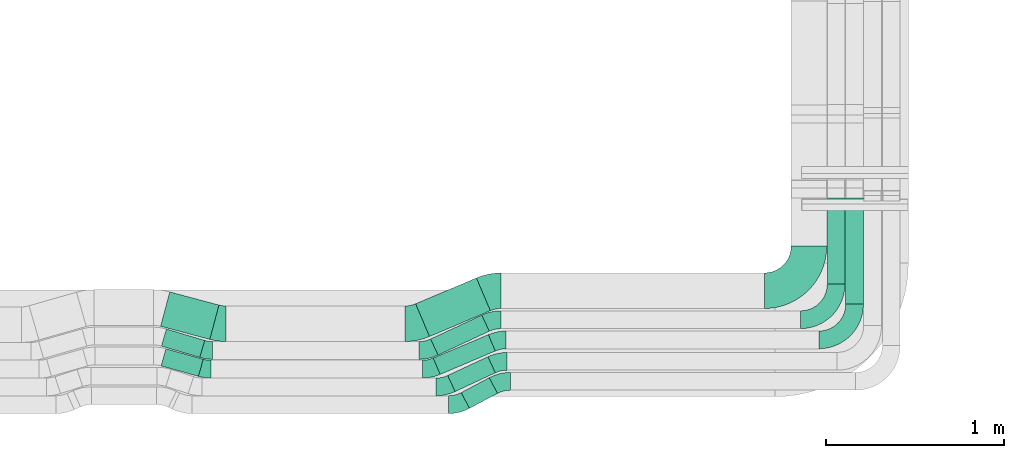
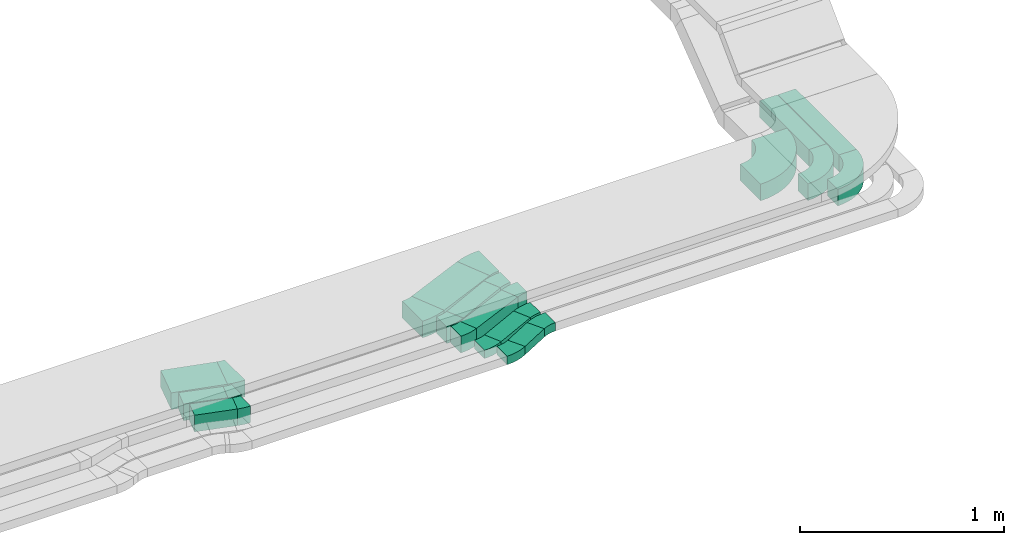
# One storey, part 23 of 38: 16 flow fittings, 10 flow segments.
"""IFC2X3 building model written with IfcOpenShell, lengths in millimetres."""

from ifc_helpers import new_model, entity, si_unit, converted_unit, derived_unit, direction, frame, frame_2d, origin, origin_2d_with_axis, place, context, subcontext, project, spatial, polyline, circle_curve, parameter, trimmed, segment, composite_curve, rectangle, outline, extrude, source, transform, mapped, material, type_object, type_shapes, element, save


model = new_model("IFC2X3")

# Units and contexts
model_context = context("Model", 3, precision=0.01, world=origin(), true_north=direction((6.12303176911189e-17, 1.0)))
body_context = subcontext(model_context, "Body", "Model", "MODEL_VIEW")
ifc_project = project(units=[si_unit("LENGTHUNIT", "METRE", prefix="MILLI"), si_unit("AREAUNIT", "SQUARE_METRE"), si_unit("VOLUMEUNIT", "CUBIC_METRE"), converted_unit("PLANEANGLEUNIT", "DEGREE", entity("IfcRatioMeasure", 0.0174532925199433), si_unit("PLANEANGLEUNIT", "RADIAN"), dimensions=[0, 0, 0, 0, 0, 0, 0]), si_unit("MASSUNIT", "GRAM", prefix="KILO"), derived_unit("MASSDENSITYUNIT", [(si_unit("MASSUNIT", "GRAM", prefix="KILO"), 1), (si_unit("LENGTHUNIT", "METRE"), -3)]), derived_unit("MOMENTOFINERTIAUNIT", [(si_unit("LENGTHUNIT", "METRE"), 4)]), si_unit("TIMEUNIT", "SECOND"), si_unit("FREQUENCYUNIT", "HERTZ"), si_unit("THERMODYNAMICTEMPERATUREUNIT", "DEGREE_CELSIUS"), derived_unit("THERMALTRANSMITTANCEUNIT", [(si_unit("MASSUNIT", "GRAM", prefix="KILO"), 1), (si_unit("THERMODYNAMICTEMPERATUREUNIT", "KELVIN"), -1), (si_unit("TIMEUNIT", "SECOND"), -3)]), derived_unit("VOLUMETRICFLOWRATEUNIT", [(si_unit("LENGTHUNIT", "METRE"), 3), (si_unit("TIMEUNIT", "SECOND"), -1)]), derived_unit("MASSFLOWRATEUNIT", [(si_unit("MASSUNIT", "GRAM", prefix="KILO"), 1), (si_unit("TIMEUNIT", "SECOND"), -1)]), derived_unit("ROTATIONALFREQUENCYUNIT", [(si_unit("TIMEUNIT", "SECOND"), -1)]), si_unit("ELECTRICCURRENTUNIT", "AMPERE"), si_unit("ELECTRICVOLTAGEUNIT", "VOLT"), si_unit("POWERUNIT", "WATT"), si_unit("FORCEUNIT", "NEWTON", prefix="KILO"), si_unit("ILLUMINANCEUNIT", "LUX"), si_unit("LUMINOUSFLUXUNIT", "LUMEN"), si_unit("LUMINOUSINTENSITYUNIT", "CANDELA"), derived_unit("USERDEFINED", [(si_unit("MASSUNIT", "GRAM", prefix="KILO"), -1), (si_unit("LENGTHUNIT", "METRE"), -2), (si_unit("TIMEUNIT", "SECOND"), 3), (si_unit("LUMINOUSFLUXUNIT", "LUMEN"), 1)]), derived_unit("LINEARVELOCITYUNIT", [(si_unit("LENGTHUNIT", "METRE"), 1), (si_unit("TIMEUNIT", "SECOND"), -1)]), si_unit("PRESSUREUNIT", "PASCAL"), derived_unit("USERDEFINED", [(si_unit("LENGTHUNIT", "METRE"), -2), (si_unit("MASSUNIT", "GRAM", prefix="KILO"), 1), (si_unit("TIMEUNIT", "SECOND"), -2)]), derived_unit("LINEARFORCEUNIT", [(si_unit("MASSUNIT", "GRAM", prefix="KILO"), 1), (si_unit("LENGTHUNIT", "METRE"), 1), (si_unit("TIMEUNIT", "SECOND"), -2), (si_unit("LENGTHUNIT", "METRE"), -1)]), derived_unit("PLANARFORCEUNIT", [(si_unit("MASSUNIT", "GRAM", prefix="KILO"), 1), (si_unit("LENGTHUNIT", "METRE"), 1), (si_unit("TIMEUNIT", "SECOND"), -2), (si_unit("LENGTHUNIT", "METRE"), -2)])], contexts=[model_context])

# Site, building, storey
site_placement = place(None, frame((0.0, -0.00077364408347762, 0.0)))
site = spatial("IfcSite", under=ifc_project, at=site_placement, CompositionType="ELEMENT")
building_placement = place(site_placement, origin())
building = spatial("IfcBuilding", under=site, at=building_placement, CompositionType="ELEMENT")
storey_placement = place(building_placement, frame((0.0, 0.0, 4200.0)))
storey = spatial("IfcBuildingStorey", under=building, at=storey_placement, CompositionType="ELEMENT", Elevation=4200.0)

# Flow segments
cable_carrier_segment_type = type_object("IfcCableCarrierSegmentType", PredefinedType="CABLETRAYSEGMENT")
flow_segment_1_placement = place(storey_placement, frame((35211.1958179256, 456.183782626173, 2836.0)))
element("IfcFlowSegment", 1, at=flow_segment_1_placement, inside=storey, type_object=cable_carrier_segment_type, context=body_context, shape_type="SweptSolid", body=[
    extrude(rectangle(XDim=217.79615928682, YDim=100.000000000001, at=frame_2d((-2.1032064978499e-12, -5.50670620214078e-13), x_axis=(1.0, 0.0))), frame((118.34592187237, 77.5079164079458, 0.0), z_axis=(0.0, 0.0, 1.0), x_axis=(-0.962971294356607, 0.269603943304174, 0.0)), (0.0, 0.0, 1.0), 100.000000000001),
])
flow_segment_2_placement = place(storey_placement, frame((35212.5847284167, 562.232941874113, 2836.0)))
element("IfcFlowSegment", 2, at=flow_segment_2_placement, inside=storey, type_object=cable_carrier_segment_type, context=body_context, shape_type="SweptSolid", body=[
    extrude(rectangle(XDim=224.770694209987, YDim=99.9999999999985, at=frame_2d((-2.07478478841949e-12, -6.11066752753686e-13), x_axis=(1.0, 0.0))), frame((121.957356239293, 79.8560646136526, 0.0), z_axis=(0.0, 0.0, 1.0), x_axis=(0.958832135501793, -0.283973477509911, 0.0)), (0.0, 0.0, 1.0), 100.000000000002),
])
flow_segment_3_placement = place(storey_placement, frame((35208.0383851297, 663.758126835801, 2836.0)))
element("IfcFlowSegment", 3, at=flow_segment_3_placement, inside=storey, type_object=cable_carrier_segment_type, context=body_context, shape_type="SweptSolid", body=[
    extrude(rectangle(XDim=286.296046062282, YDim=199.999999999998, at=origin_2d_with_axis()), frame((164.09770918438, 133.539093716074, 0.0), z_axis=(0.0, 0.0, 1.0), x_axis=(0.966162315070978, -0.257934838547816, 0.0)), (0.0, 0.0, 1.0), 100.0),
])
flow_segment_4_placement = place(storey_placement, frame((36897.7556908451, 276.389575620058, 2836.0)))
element("IfcFlowSegment", 4, at=flow_segment_4_placement, inside=storey, type_object=cable_carrier_segment_type, context=body_context, shape_type="SweptSolid", body=[
    extrude(rectangle(XDim=178.268798862719, YDim=99.9999999999956, at=frame_2d((0.0, -1.4210854715202e-14), x_axis=(1.0, 0.0))), frame((102.174581558138, 85.9934454419745, 0.0), z_axis=(0.0, 0.0, 1.0), x_axis=(0.882947592858864, 0.46947156278601, 0.0)), (0.0, 0.0, 1.0), 49.9999999999995),
])
flow_segment_5_placement = place(storey_placement, frame((36821.7823745503, 370.502673774555, 2836.0)))
element("IfcFlowSegment", 5, at=flow_segment_5_placement, inside=storey, type_object=cable_carrier_segment_type, context=body_context, shape_type="SweptSolid", body=[
    extrude(rectangle(XDim=249.322134942816, YDim=100.0, at=frame_2d((3.92930132875335e-12, -1.82964754458226e-12), x_axis=(1.0, 0.0))), frame((134.112209276668, 97.9994329933472, 0.0), z_axis=(0.0, 0.0, 1.0), x_axis=(0.906307787036612, 0.422618261740782, 0.0)), (0.0, 0.0, 1.0), 49.9999999999995),
])
flow_segment_6_placement = place(storey_placement, frame((36740.6619742729, 466.921520037423, 2836.0)))
element("IfcFlowSegment", 6, at=flow_segment_6_placement, inside=storey, type_object=cable_carrier_segment_type, context=body_context, shape_type="SweptSolid", body=[
    extrude(rectangle(XDim=336.619080230507, YDim=100.000000000003, at=origin_2d_with_axis()), frame((174.466304982903, 111.789019217376, 0.0), z_axis=(0.0, 0.0, 1.0), x_axis=(0.920504853452414, 0.390731128489335, 0.0)), (0.0, 0.0, 1.0), 99.9999999999989),
])
flow_segment_7_placement = place(storey_placement, frame((36725.6985726466, 575.502673774658, 2836.0)))
element("IfcFlowSegment", 7, at=flow_segment_7_placement, inside=storey, type_object=cable_carrier_segment_type, context=body_context, shape_type="SweptSolid", body=[
    extrude(rectangle(XDim=317.491127027028, YDim=100.000000000002, at=frame_2d((-1.93267624126747e-12, 9.73443547991337e-13), x_axis=(1.0, 0.0))), frame((165.003253456849, 112.404163462983, 0.0), z_axis=(0.0, 0.0, 1.0), x_axis=(0.906307787036578, 0.422618261740854, 0.0)), (0.0, 0.0, 1.0), 99.9999999999989),
])
flow_segment_8_placement = place(storey_placement, frame((36641.7605532105, 679.871034692253, 2836.0)))
element("IfcFlowSegment", 8, at=flow_segment_8_placement, inside=storey, type_object=cable_carrier_segment_type, context=body_context, shape_type="SweptSolid", body=[
    extrude(rectangle(XDim=371.273850288119, YDim=200.000000000002, at=origin_2d_with_axis()), frame((209.952803424025, 164.584610596079, 0.0), z_axis=(0.0, 0.0, 1.0), x_axis=(0.920504853452391, 0.390731128489391, 0.0)), (0.0, 0.0, 1.0), 99.9999999999989),
])
flow_segment_9_placement = place(storey_placement, frame((38955.522261068, 975.156672202695, 2836.0)))
element("IfcFlowSegment", 9, at=flow_segment_9_placement, inside=storey, type_object=cable_carrier_segment_type, context=body_context, shape_type="SweptSolid", body=[
    extrude(rectangle(XDim=483.697987779562, YDim=100.000000000003, at=frame_2d((1.27897692436818e-13, 0.0), x_axis=(1.0, 0.0))), frame((50.0, 241.848993890255, 0.0), z_axis=(0.0, 0.0, 1.0), x_axis=(0.0, 1.0, 0.0)), (0.0, 0.0, 1.0), 100.0),
])
flow_segment_10_placement = place(storey_placement, frame((39058.8222600307, 861.76407623751, 2836.0)))
element("IfcFlowSegment", 10, at=flow_segment_10_placement, inside=storey, type_object=cable_carrier_segment_type, context=body_context, shape_type="SweptSolid", body=[
    extrude(rectangle(XDim=597.090583745162, YDim=99.9999999999946, at=frame_2d((0.0, -4.33075797445781e-12), x_axis=(1.0, 0.0))), frame((50.0, 298.545291872581, 0.0), z_axis=(0.0, 0.0, 1.0), x_axis=(0.0, 1.0, 0.0)), (0.0, 0.0, 1.0), 99.9999999999989),
])

# Flow fittings
ifc_material = material()
cable_carrier_fitting_type_1 = type_object("IfcCableCarrierFittingType", Name="470_DKC_S5_Variable Angle Elbow 0-45:-", PredefinedType="NOTDEFINED", material=ifc_material)
shared_shape_1 = source(origin(), body_context, "Body", "SweptSolid", [
    extrude(outline(composite_curve([segment(polyline([(-125.750000000001, -225.25), (-124.749999999999, -225.25)]), True, "CONTINUOUS"), segment(trimmed(circle_curve(frame_2d((-124.75, 124.75), x_axis=(0.0, -1.0)), 350.0), [parameter(0.0)], [parameter(90.0000000000001)], True, "PARAMETER"), True, "CONTINUOUS"), segment(polyline([(225.25, 124.75), (225.25, 125.749999999999)]), True, "CONTINUOUS"), segment(polyline([(225.25, 125.749999999999), (25.25, 125.750000000001)]), True, "CONTINUOUS"), segment(polyline([(25.25, 125.750000000001), (25.25, 124.75)]), True, "CONTINUOUS"), segment(trimmed(circle_curve(frame_2d((-124.75, 124.75), x_axis=(0.0, -1.0)), 150.0), [parameter(0.0)], [parameter(90.0000000000001)], True, "PARAMETER"), False, "CONTINUOUS"), segment(polyline([(-124.749999999999, -25.2500000000003), (-125.750000000001, -25.2500000000003)]), True, "CONTINUOUS"), segment(polyline([(-125.750000000001, -25.2500000000003), (-125.750000000001, -225.25)]), True, "CONTINUOUS")], self_intersect=False)), frame((-125.249999999991, 125.249999999992, -50.0)), (0.0, 0.0, 1.0), 100.0),
])
type_shapes(cable_carrier_fitting_type_1, [shared_shape_1])
flow_fitting_1_placement = place(storey_placement, frame((38852.8222600308, 937.254288304516, 2886.0)))
element("IfcFlowFitting", 11, at=flow_fitting_1_placement, inside=storey, type_object=cable_carrier_fitting_type_1, material=ifc_material, Name="470_DKC_S5_Variable Angle Elbow 0-45:-", ObjectType="470_DKC_S5_Variable Angle Elbow 0-45:-", context=body_context, shape_type="MappedRepresentation", body=[
    mapped(shared_shape_1, transform((0.0, 0.0, 0.0), scale=1.0)),
])
cable_carrier_fitting_type_2 = type_object("IfcCableCarrierFittingType", Name="470_DKC_S5_Variable Angle Elbow 0-45:-", PredefinedType="NOTDEFINED", material=ifc_material)
shared_shape_2 = source(origin(), body_context, "Body", "SweptSolid", [
    extrude(outline(composite_curve([segment(polyline([(-100.749999999999, -150.250000000001), (-99.7499999999981, -150.250000000001)]), True, "CONTINUOUS"), segment(trimmed(circle_curve(frame_2d((-99.7500000000006, 99.7499999999987), x_axis=(0.0, -1.0)), 250.0), [parameter(0.0)], [parameter(90.0000000000001)], True, "PARAMETER"), True, "CONTINUOUS"), segment(polyline([(150.249999999999, 99.7500000000013), (150.249999999999, 100.750000000001)]), True, "CONTINUOUS"), segment(polyline([(150.249999999999, 100.750000000001), (50.2499999999992, 100.750000000001)]), True, "CONTINUOUS"), segment(polyline([(50.2499999999992, 100.750000000001), (50.2499999999992, 99.7500000000002)]), True, "CONTINUOUS"), segment(trimmed(circle_curve(frame_2d((-99.7500000000006, 99.7499999999987), x_axis=(0.0, -1.0)), 150.0), [parameter(0.0)], [parameter(90.0000000000001)], True, "PARAMETER"), False, "CONTINUOUS"), segment(polyline([(-99.7499999999989, -50.2500000000011), (-100.75, -50.2500000000011)]), True, "CONTINUOUS"), segment(polyline([(-100.75, -50.2500000000011), (-100.749999999999, -150.250000000001)]), True, "CONTINUOUS")], self_intersect=False)), frame((-100.249999999991, 100.249999999992, -50.0)), (0.0, 0.0, 1.0), 100.0),
])
type_shapes(cable_carrier_fitting_type_2, [shared_shape_2])
for number, where, name in (
    (12, (39005.5222610726, 774.156672203185, 2886.0), "470_DKC_S5_Variable Angle Elbow 0-45:-"),
    (13, (39108.8222600307, 660.764076237527, 2886.0), "470_DKC_S5_Variable Angle Elbow 0-45:-"),
):
    element("IfcFlowFitting", number, at=place(storey_placement, frame(where)), inside=storey, type_object=cable_carrier_fitting_type_2, material=ifc_material, Name=name, ObjectType="470_DKC_S5_Variable Angle Elbow 0-45:-", context=body_context, shape_type="MappedRepresentation", body=[
        mapped(shared_shape_2, transform((0.0, 0.0, 0.0), scale=1.0)),
    ])
cable_carrier_fitting_type_3 = type_object("IfcCableCarrierFittingType", Name="470_DKC_S5_Variable Angle Elbow 0-45:-", PredefinedType="NOTDEFINED", material=ifc_material)
shared_shape_3 = source(origin(), body_context, "Body", "SweptSolid", [
    extrude(outline(composite_curve([segment(polyline([(-43.2384031208295, -59.47487586177), (-42.2384031208282, -59.47487586177)]), True, "CONTINUOUS"), segment(trimmed(circle_curve(frame_2d((-42.2384031208287, 190.52512413823), x_axis=(0.0, -1.0)), 250.0), [parameter(0.0)], [parameter(24.9999999999996)], True, "PARAMETER"), True, "CONTINUOUS"), segment(polyline([(63.4161623143451, -36.0518226209329), (64.3224701013807, -35.6292043591927)]), True, "CONTINUOUS"), segment(polyline([(64.3224701013807, -35.6292043591928), (22.0606439273132, 55.0015743444733)]), True, "CONTINUOUS"), segment(polyline([(22.0606439273133, 55.0015743444733), (21.1543361402755, 54.5789560827322)]), True, "CONTINUOUS"), segment(trimmed(circle_curve(frame_2d((-42.2384031208287, 190.52512413823), x_axis=(0.0, -1.0)), 150.0), [parameter(0.0)], [parameter(24.9999999999996)], True, "PARAMETER"), False, "CONTINUOUS"), segment(polyline([(-42.2384031208282, 40.5251241382299), (-43.2384031208295, 40.5251241382299)]), True, "CONTINUOUS"), segment(polyline([(-43.2384031208295, 40.5251241382299), (-43.2384031208295, -59.47487586177)]), True, "CONTINUOUS")], self_intersect=False)), frame((-2.10052940774906, 9.47487586176191, -25.0)), (0.0, 0.0, 1.0), 50.0),
])
type_shapes(cable_carrier_fitting_type_3, [shared_shape_3])
flow_fitting_2_placement = place(storey_placement, frame((36801.8222600308, 396.657002271991, 2861.0)))
element("IfcFlowFitting", 14, at=flow_fitting_2_placement, inside=storey, type_object=cable_carrier_fitting_type_3, material=ifc_material, Name="470_DKC_S5_Variable Angle Elbow 0-45:-", ObjectType="470_DKC_S5_Variable Angle Elbow 0-45:-", context=body_context, shape_type="MappedRepresentation", body=[
    mapped(shared_shape_3, transform((0.0, 0.0, 0.0), scale=1.0)),
])
flow_fitting_3_placement = place(storey_placement, frame((37109.9669076233, 540.347211263812, 2861.0), z_axis=(0.0, 0.0, 1.0), x_axis=(-1.0, 0.0, 0.0)))
element("IfcFlowFitting", 15, at=flow_fitting_3_placement, inside=storey, type_object=cable_carrier_fitting_type_3, material=ifc_material, Name="470_DKC_S5_Variable Angle Elbow 0-45:-", ObjectType="470_DKC_S5_Variable Angle Elbow 0-45:-", context=body_context, shape_type="MappedRepresentation", body=[
    mapped(shared_shape_3, transform((0.0, 0.0, 0.0), scale=1.0)),
])
cable_carrier_fitting_type_4 = type_object("IfcCableCarrierFittingType", Name="470_DKC_S5_Variable Angle Elbow 0-45:-", PredefinedType="NOTDEFINED", material=ifc_material)
shared_shape_4 = source(origin(), body_context, "Body", "SweptSolid", [
    extrude(outline(composite_curve([segment(polyline([(-27.9511371539973, -53.7702715501628), (-26.951137153996, -53.7702715501628)]), True, "CONTINUOUS"), segment(trimmed(circle_curve(frame_2d((-26.9511371539986, 196.229728449837), x_axis=(0.0, -1.0)), 250.0), [parameter(0.0)], [parameter(15.6407005368424)], True, "PARAMETER"), True, "CONTINUOUS"), segment(polyline([(40.4498486720227, -44.5130951393208), (41.4128199663793, -44.2434911960168)]), True, "CONTINUOUS"), segment(polyline([(41.4128199663793, -44.2434911960168), (14.4524256359709, 52.0536382396464)]), True, "CONTINUOUS"), segment(polyline([(14.4524256359709, 52.0536382396464), (13.4894543416142, 51.7840342963423)]), True, "CONTINUOUS"), segment(trimmed(circle_curve(frame_2d((-26.9511371539986, 196.229728449837), x_axis=(0.0, -1.0)), 150.0), [parameter(0.0)], [parameter(15.6407005368424)], True, "PARAMETER"), False, "CONTINUOUS"), segment(polyline([(-26.9511371539968, 46.2297284498371), (-27.9511371539982, 46.2297284498371)]), True, "CONTINUOUS"), segment(polyline([(-27.9511371539982, 46.2297284498371), (-27.9511371539973, -53.7702715501628)]), True, "CONTINUOUS")], self_intersect=False)), frame((-0.517827275495085, 3.77027155015447, -50.0)), (0.0, 0.0, 1.0), 100.0),
])
type_shapes(cable_carrier_fitting_type_4, [shared_shape_4])
flow_fitting_4_placement = place(storey_placement, frame((35461.8222600308, 496.657002272046, 2886.0), z_axis=(0.0, 0.0, 1.0), x_axis=(0.962971294356626, -0.269603943304108, 0.0)))
element("IfcFlowFitting", 16, at=flow_fitting_4_placement, inside=storey, type_object=cable_carrier_fitting_type_4, material=ifc_material, Name="470_DKC_S5_Variable Angle Elbow 0-45:-", ObjectType="470_DKC_S5_Variable Angle Elbow 0-45:-", context=body_context, shape_type="MappedRepresentation", body=[
    mapped(shared_shape_4, transform((0.0, 0.0, 0.0), scale=1.0)),
])
cable_carrier_fitting_type_5 = type_object("IfcCableCarrierFittingType", Name="470_DKC_S5_Variable Angle Elbow 0-45:-", PredefinedType="NOTDEFINED", material=ifc_material)
shared_shape_5 = source(origin(), body_context, "Body", "SweptSolid", [
    extrude(outline(composite_curve([segment(polyline([(-29.3870557848613, -54.1877798191967), (-28.38705578486, -54.1877798191967)]), True, "CONTINUOUS"), segment(trimmed(circle_curve(frame_2d((-28.3870557848626, 195.812220180803), x_axis=(0.0, -1.0)), 250.0), [parameter(0.0)], [parameter(16.4974981762259)], True, "PARAMETER"), True, "CONTINUOUS"), segment(polyline([(42.606313592603, -43.8958136946485), (43.5651457281047, -43.6118402171386)]), True, "CONTINUOUS"), segment(polyline([(43.5651457281047, -43.6118402171387), (15.1677979771187, 52.271373333042)]), True, "CONTINUOUS"), segment(polyline([(15.1677979771187, 52.271373333042), (14.2089658416168, 51.9873998555321)]), True, "CONTINUOUS"), segment(trimmed(circle_curve(frame_2d((-28.3870557848626, 195.812220180803), x_axis=(0.0, -1.0)), 150.0), [parameter(0.0)], [parameter(16.4974981762259)], True, "PARAMETER"), False, "CONTINUOUS"), segment(polyline([(-28.3870557848609, 45.8122201808031), (-29.3870557848622, 45.8122201808031)]), True, "CONTINUOUS"), segment(polyline([(-29.3870557848622, 45.8122201808031), (-29.3870557848613, -54.1877798191967)]), True, "CONTINUOUS")], self_intersect=False)), frame((-0.607105824297182, 4.18777981918844, -50.0)), (0.0, 0.0, 1.0), 100.0),
])
type_shapes(cable_carrier_fitting_type_5, [shared_shape_5])
flow_fitting_5_placement = place(storey_placement, frame((35471.0601330481, 601.657002272074, 2886.0), z_axis=(0.0, 0.0, 1.0), x_axis=(0.958832135501802, -0.28397347750988, 0.0)))
element("IfcFlowFitting", 17, at=flow_fitting_5_placement, inside=storey, type_object=cable_carrier_fitting_type_5, material=ifc_material, Name="470_DKC_S5_Variable Angle Elbow 0-45:-", ObjectType="470_DKC_S5_Variable Angle Elbow 0-45:-", context=body_context, shape_type="MappedRepresentation", body=[
    mapped(shared_shape_5, transform((0.0, 0.0, 0.0), scale=1.0)),
])
cable_carrier_fitting_type_6 = type_object("IfcCableCarrierFittingType", Name="470_DKC_S5_Variable Angle Elbow 0-45:-", PredefinedType="NOTDEFINED", material=ifc_material)
shared_shape_6 = source(origin(), body_context, "Body", "SweptSolid", [
    extrude(outline(composite_curve([segment(polyline([(-33.233395397237, -104.294194325762), (-32.2333953972356, -104.294194325762)]), True, "CONTINUOUS"), segment(trimmed(circle_curve(frame_2d((-32.2333953972362, 245.705805674237), x_axis=(0.0, -1.0)), 350.0), [parameter(0.0)], [parameter(14.9475579822834)], True, "PARAMETER"), True, "CONTINUOUS"), segment(polyline([(58.0437980944752, -92.4510046006111), (59.0099604095462, -92.1930697620634)]), True, "CONTINUOUS"), segment(polyline([(59.0099604095462, -92.1930697620634), (7.4229926999968, 101.039393252136)]), True, "CONTINUOUS"), segment(polyline([(7.42299269999681, 101.039393252136), (6.45683038492583, 100.781458413588)]), True, "CONTINUOUS"), segment(trimmed(circle_curve(frame_2d((-32.2333953972362, 245.705805674237), x_axis=(0.0, -1.0)), 150.0), [parameter(0.0)], [parameter(14.9475579822834)], True, "PARAMETER"), False, "CONTINUOUS"), segment(polyline([(-32.2333953972356, 95.7058056742375), (-33.233395397237, 95.7058056742375)]), True, "CONTINUOUS"), segment(polyline([(-33.233395397237, 95.7058056742375), (-33.233395397237, -104.294194325762)]), True, "CONTINUOUS")], self_intersect=False)), frame((-0.563342258977596, 4.29419432575427, -50.0)), (0.0, 0.0, 1.0), 100.0),
])
type_shapes(cable_carrier_fitting_type_6, [shared_shape_6])
flow_fitting_6_placement = place(storey_placement, frame((35543.0934539395, 751.657002272118, 2886.0), z_axis=(0.0, 0.0, 1.0), x_axis=(0.966162315070988, -0.25793483854778, 0.0)))
element("IfcFlowFitting", 18, at=flow_fitting_6_placement, inside=storey, type_object=cable_carrier_fitting_type_6, material=ifc_material, Name="470_DKC_S5_Variable Angle Elbow 0-45:-", ObjectType="470_DKC_S5_Variable Angle Elbow 0-45:-", context=body_context, shape_type="MappedRepresentation", body=[
    mapped(shared_shape_6, transform((0.0, 0.0, 0.0), scale=1.0)),
])
cable_carrier_fitting_type_7 = type_object("IfcCableCarrierFittingType", Name="470_DKC_S5_Variable Angle Elbow 0-45:-", PredefinedType="NOTDEFINED", material=ifc_material)
shared_shape_7 = source(origin(), body_context, "Body", "SweptSolid", [
    extrude(outline(composite_curve([segment(polyline([(-47.9178931768045, -61.8226086048037), (-46.9178931768032, -61.8226086048037)]), True, "CONTINUOUS"), segment(trimmed(circle_curve(frame_2d((-46.9178931768036, 188.177391395196), x_axis=(0.0, -1.0)), 250.0), [parameter(0.0)], [parameter(27.9999999999998)], True, "PARAMETER"), True, "CONTINUOUS"), segment(polyline([(70.4499975196686, -32.5595068195356), (71.3329451125274, -32.0900352567498)]), True, "CONTINUOUS"), segment(polyline([(71.3329451125274, -32.0900352567498), (24.3857888339387, 56.204724029143)]), True, "CONTINUOUS"), segment(polyline([(24.3857888339387, 56.204724029143), (23.5028412410797, 55.735252466357)]), True, "CONTINUOUS"), segment(trimmed(circle_curve(frame_2d((-46.9178931768036, 188.177391395196), x_axis=(0.0, -1.0)), 150.0), [parameter(0.0)], [parameter(27.9999999999998)], True, "PARAMETER"), False, "CONTINUOUS"), segment(polyline([(-46.9178931768032, 38.1773913951962), (-47.9178931768045, 38.1773913951962)]), True, "CONTINUOUS"), segment(polyline([(-47.9178931768045, 38.1773913951962), (-47.9178931768045, -61.8226086048037)]), True, "CONTINUOUS")], self_intersect=False)), frame((-2.94770739182255, 11.8226086047956, -25.0)), (0.0, 0.0, 1.0), 50.0),
])
type_shapes(cable_carrier_fitting_type_7, [shared_shape_7])
flow_fitting_7_placement = place(storey_placement, frame((36876.317609403, 296.657002272016, 2861.0)))
element("IfcFlowFitting", 19, at=flow_fitting_7_placement, inside=storey, type_object=cable_carrier_fitting_type_7, material=ifc_material, Name="470_DKC_S5_Variable Angle Elbow 0-45:-", ObjectType="470_DKC_S5_Variable Angle Elbow 0-45:-", context=body_context, shape_type="MappedRepresentation", body=[
    mapped(shared_shape_7, transform((0.0, 0.0, 0.0), scale=1.0)),
])
flow_fitting_8_placement = place(storey_placement, frame((37123.5429354035, 428.109039852049, 2861.0), z_axis=(0.0, 0.0, 1.0), x_axis=(-1.0, 0.0, 0.0)))
element("IfcFlowFitting", 20, at=flow_fitting_8_placement, inside=storey, type_object=cable_carrier_fitting_type_7, material=ifc_material, Name="470_DKC_S5_Variable Angle Elbow 0-45:-", ObjectType="470_DKC_S5_Variable Angle Elbow 0-45:-", context=body_context, shape_type="MappedRepresentation", body=[
    mapped(shared_shape_7, transform((0.0, 0.0, 0.0), scale=1.0)),
])
cable_carrier_fitting_type_8 = type_object("IfcCableCarrierFittingType", Name="470_DKC_S5_Variable Angle Elbow 0-45:-", PredefinedType="NOTDEFINED", material=ifc_material)
shared_shape_8 = source(origin(), body_context, "Body", "SweptSolid", [
    extrude(outline(composite_curve([segment(polyline([(-40.053239062291, -58.0471974368787), (-39.0532390622896, -58.0471974368787)]), True, "CONTINUOUS"), segment(trimmed(circle_curve(frame_2d((-39.0532390622922, 191.952802563121), x_axis=(0.0, -1.0)), 250.0), [parameter(0.0)], [parameter(23.0)], True, "PARAMETER"), True, "CONTINUOUS"), segment(polyline([(58.6295430600284, -38.1734107999878), (59.5500479134806, -37.7826796714986)]), True, "CONTINUOUS"), segment(polyline([(59.5500479134806, -37.7826796714986), (20.4769350645528, 54.2678056737451)]), True, "CONTINUOUS"), segment(polyline([(20.4769350645528, 54.2678056737451), (19.5564302111001, 53.8770745452558)]), True, "CONTINUOUS"), segment(trimmed(circle_curve(frame_2d((-39.0532390622922, 191.952802563121), x_axis=(0.0, -1.0)), 150.0), [parameter(0.0)], [parameter(23.0)], True, "PARAMETER"), False, "CONTINUOUS"), segment(polyline([(-39.0532390622905, 41.9528025631212), (-40.0532390622918, 41.9528025631212)]), True, "CONTINUOUS"), segment(polyline([(-40.0532390622918, 41.9528025631212), (-40.053239062291, -58.0471974368787)]), True, "CONTINUOUS")], self_intersect=False)), frame((-1.63722082243965, 8.04719743687026, -50.0)), (0.0, 0.0, 1.0), 100.0),
])
type_shapes(cable_carrier_fitting_type_8, [shared_shape_8])
flow_fitting_9_placement = place(storey_placement, frame((36721.8222600308, 496.65700227206, 2886.0)))
element("IfcFlowFitting", 21, at=flow_fitting_9_placement, inside=storey, type_object=cable_carrier_fitting_type_8, material=ifc_material, Name="470_DKC_S5_Variable Angle Elbow 0-45:-", ObjectType="470_DKC_S5_Variable Angle Elbow 0-45:-", context=body_context, shape_type="MappedRepresentation", body=[
    mapped(shared_shape_8, transform((0.0, 0.0, 0.0), scale=1.0)),
])
flow_fitting_10_placement = place(storey_placement, frame((37108.4342984808, 660.764076237538, 2886.0), z_axis=(0.0, 0.0, 1.0), x_axis=(-1.0, 0.0, 0.0)))
element("IfcFlowFitting", 22, at=flow_fitting_10_placement, inside=storey, type_object=cable_carrier_fitting_type_8, material=ifc_material, Name="470_DKC_S5_Variable Angle Elbow 0-45:-", ObjectType="470_DKC_S5_Variable Angle Elbow 0-45:-", context=body_context, shape_type="MappedRepresentation", body=[
    mapped(shared_shape_8, transform((0.0, 0.0, 0.0), scale=1.0)),
])
cable_carrier_fitting_type_9 = type_object("IfcCableCarrierFittingType", Name="470_DKC_S5_Variable Angle Elbow 0-45:-", PredefinedType="NOTDEFINED", material=ifc_material)
shared_shape_9 = source(origin(), body_context, "Body", "SweptSolid", [
    extrude(outline(composite_curve([segment(polyline([(-43.2384031208381, -59.4748758617746), (-42.2384031208368, -59.4748758617746)]), True, "CONTINUOUS"), segment(trimmed(circle_curve(frame_2d((-42.2384031208394, 190.525124138225), x_axis=(0.0, -1.0)), 250.0), [parameter(0.0)], [parameter(25.0000000000054)], True, "PARAMETER"), True, "CONTINUOUS"), segment(polyline([(63.416162314359, -36.0518226209261), (64.3224701013944, -35.6292043591859)]), True, "CONTINUOUS"), segment(polyline([(64.3224701013944, -35.6292043591859), (22.0606439273174, 55.0015743444757)]), True, "CONTINUOUS"), segment(polyline([(22.0606439273174, 55.0015743444757), (21.1543361402796, 54.5789560827344)]), True, "CONTINUOUS"), segment(trimmed(circle_curve(frame_2d((-42.2384031208394, 190.525124138225), x_axis=(0.0, -1.0)), 150.0), [parameter(0.0)], [parameter(25.0000000000054)], True, "PARAMETER"), False, "CONTINUOUS"), segment(polyline([(-42.2384031208376, 40.5251241382253), (-43.2384031208389, 40.5251241382253)]), True, "CONTINUOUS"), segment(polyline([(-43.2384031208389, 40.5251241382253), (-43.2384031208381, -59.4748758617746)]), True, "CONTINUOUS")], self_intersect=False)), frame((-2.10052940775049, 9.47487586176616, -50.0)), (0.0, 0.0, 1.0), 100.0),
])
type_shapes(cable_carrier_fitting_type_9, [shared_shape_9])
flow_fitting_11_placement = place(storey_placement, frame((36705.738458127, 601.657002272085, 2886.0)))
element("IfcFlowFitting", 23, at=flow_fitting_11_placement, inside=storey, type_object=cable_carrier_fitting_type_9, material=ifc_material, Name="470_DKC_S5_Variable Angle Elbow 0-45:-", ObjectType="470_DKC_S5_Variable Angle Elbow 0-45:-", context=body_context, shape_type="MappedRepresentation", body=[
    mapped(shared_shape_9, transform((0.0, 0.0, 0.0), scale=1.0)),
])
flow_fitting_12_placement = place(storey_placement, frame((37075.6651940798, 774.156672203197, 2886.0), z_axis=(0.0, 0.0, 1.0), x_axis=(-1.0, 0.0, 0.0)))
element("IfcFlowFitting", 24, at=flow_fitting_12_placement, inside=storey, type_object=cable_carrier_fitting_type_9, material=ifc_material, Name="470_DKC_S5_Variable Angle Elbow 0-45:-", ObjectType="470_DKC_S5_Variable Angle Elbow 0-45:-", context=body_context, shape_type="MappedRepresentation", body=[
    mapped(shared_shape_9, transform((0.0, 0.0, 0.0), scale=1.0)),
])
cable_carrier_fitting_type_10 = type_object("IfcCableCarrierFittingType", Name="470_DKC_S5_Variable Angle Elbow 0-45:-", PredefinedType="NOTDEFINED", material=ifc_material)
shared_shape_10 = source(origin(), body_context, "Body", "SweptSolid", [
    extrude(outline(composite_curve([segment(polyline([(-49.8215172745315, -110.034576100571), (-48.82151727453, -110.034576100571)]), True, "CONTINUOUS"), segment(trimmed(circle_curve(frame_2d((-48.8215172745307, 239.965423899429), x_axis=(0.0, -1.0)), 350.0), [parameter(0.0)], [parameter(23.000000000004)], True, "PARAMETER"), True, "CONTINUOUS"), segment(polyline([(87.9343776967383, -82.2112748089151), (88.8548825501907, -81.8205436804257)]), True, "CONTINUOUS"), segment(polyline([(88.8548825501907, -81.8205436804258), (10.7086568523226, 102.280427010057)]), True, "CONTINUOUS"), segment(polyline([(10.7086568523227, 102.280427010057), (9.78815199887027, 101.889695881567)]), True, "CONTINUOUS"), segment(trimmed(circle_curve(frame_2d((-48.8215172745307, 239.965423899429), x_axis=(0.0, -1.0)), 150.0), [parameter(0.0)], [parameter(23.000000000004)], True, "PARAMETER"), False, "CONTINUOUS"), segment(polyline([(-48.82151727453, 89.9654238994291), (-49.8215172745315, 89.9654238994291)]), True, "CONTINUOUS"), segment(polyline([(-49.8215172745315, 89.9654238994291), (-49.8215172745315, -110.034576100571)]), True, "CONTINUOUS")], self_intersect=False)), frame((-2.04155758139369, 10.0345761005627, -50.0)), (0.0, 0.0, 1.0), 100.0),
])
type_shapes(cable_carrier_fitting_type_10, [shared_shape_10])
flow_fitting_13_placement = place(storey_placement, frame((36633.0934539395, 751.657002272123, 2886.0)))
element("IfcFlowFitting", 25, at=flow_fitting_13_placement, inside=storey, type_object=cable_carrier_fitting_type_10, material=ifc_material, Name="470_DKC_S5_Variable Angle Elbow 0-45:-", ObjectType="470_DKC_S5_Variable Angle Elbow 0-45:-", context=body_context, shape_type="MappedRepresentation", body=[
    mapped(shared_shape_10, transform((0.0, 0.0, 0.0), scale=1.0)),
])
flow_fitting_14_placement = place(storey_placement, frame((37070.3332593294, 937.254288304541, 2886.0), z_axis=(0.0, 0.0, 1.0), x_axis=(-1.0, 0.0, 0.0)))
element("IfcFlowFitting", 26, at=flow_fitting_14_placement, inside=storey, type_object=cable_carrier_fitting_type_10, material=ifc_material, Name="470_DKC_S5_Variable Angle Elbow 0-45:-", ObjectType="470_DKC_S5_Variable Angle Elbow 0-45:-", context=body_context, shape_type="MappedRepresentation", body=[
    mapped(shared_shape_10, transform((0.0, 0.0, 0.0), scale=1.0)),
])

save(model, "model.ifc")
